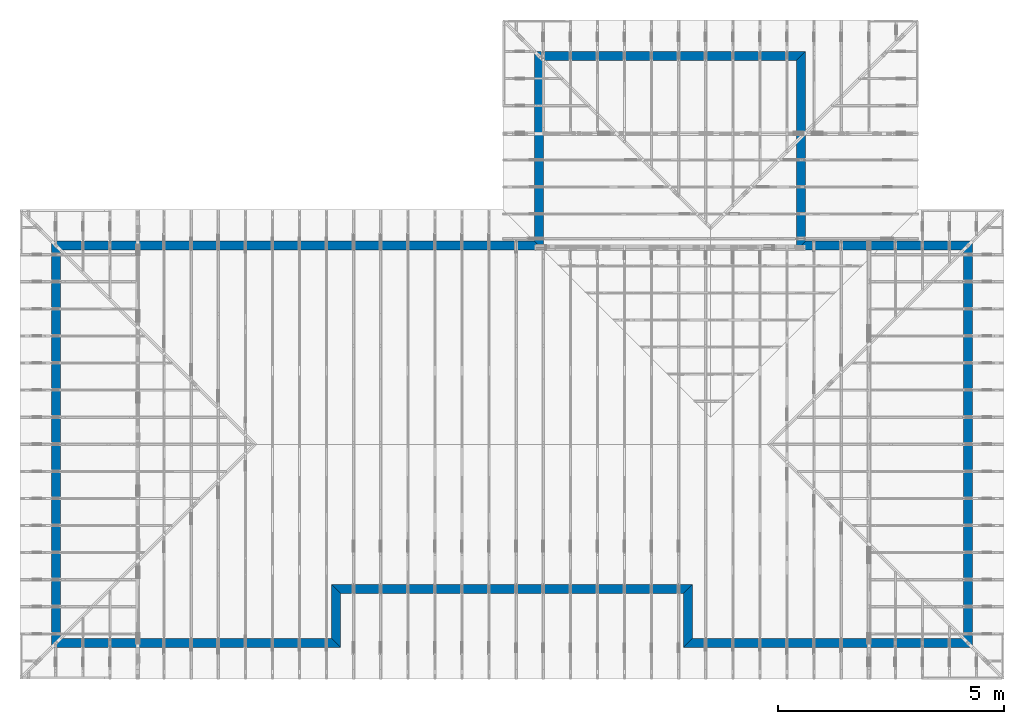
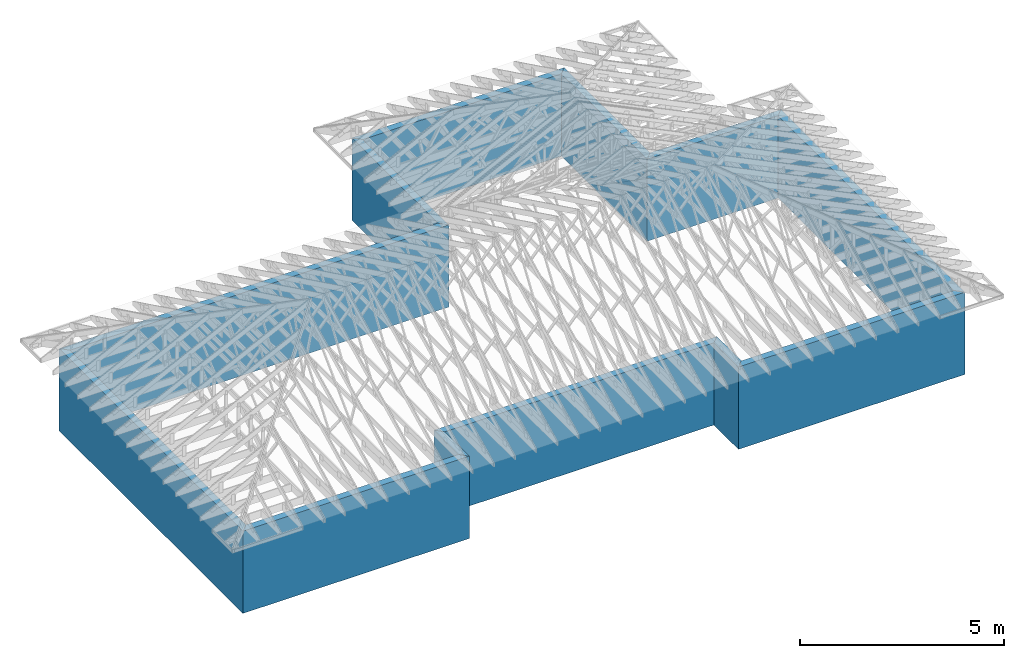
# One storey, part 1 of 159: 12 walls.
"""IFC2X3 building model written with IfcOpenShell, lengths in millimetres."""

from ifc_helpers import new_model, si_unit, frame, origin, origin_with_axes, origin_2d, place, context, project, spatial, polyline, segment, composite_curve, outline, extrude, material, layer, layer_set, layer_usage, type_object, element, save


model = new_model("IFC2X3")

# Units and contexts
model_context = context("Model", 3, precision=1e-05, world=origin())
plan_context = context("Plan", 2, precision=1e-05, world=origin_2d())
ifc_project = project(units=[si_unit("LENGTHUNIT", "METRE", prefix="MILLI"), si_unit("AREAUNIT", "SQUARE_METRE"), si_unit("VOLUMEUNIT", "CUBIC_METRE"), si_unit("SOLIDANGLEUNIT", "STERADIAN"), si_unit("PLANEANGLEUNIT", "RADIAN"), si_unit("MASSUNIT", "GRAM"), si_unit("TIMEUNIT", "SECOND"), si_unit("THERMODYNAMICTEMPERATUREUNIT", "DEGREE_CELSIUS"), si_unit("LUMINOUSINTENSITYUNIT", "LUMEN")], contexts=[model_context, plan_context])

# Site, building, storey
site_placement = place(None, origin_with_axes())
site = spatial("IfcSite", under=ifc_project, at=site_placement, CompositionType="ELEMENT")
building_placement = place(site_placement, origin_with_axes())
building = spatial("IfcBuilding", under=site, at=building_placement, Name="Plan 1", CompositionType="ELEMENT")
storey_placement = place(building_placement, origin_with_axes())
storey = spatial("IfcBuildingStorey", under=building, at=storey_placement, Name="Etasje 1", CompositionType="ELEMENT", Elevation=0.0)

# Walls
ifc_material = material(Name="Framing")
ifc_layer = layer(ifc_material, 198.0)
ifc_layer_set = layer_set([ifc_layer])
ifc_layer_usage_1 = layer_usage(ifc_layer_set, "AXIS2", "POSITIVE", 0.0)
wall_type = type_object("IfcWallType", Name="YV198", PredefinedType="STANDARD", material=ifc_layer_set)
wall_1_placement = place(storey_placement, frame((14000.012695802194, 0.001069870516026506, -2458.0), z_axis=(0.0, 0.0, 1.0), x_axis=(1.0, 0.0, 0.0)))
element("IfcWallStandardCase", 1, at=wall_1_placement, inside=storey, type_object=wall_type, material=ifc_layer_usage_1, Name="Vegg 1", context=model_context, shape_type="SweptSolid", body=[
    extrude(outline(composite_curve([segment(polyline([(198.0, 198.0), (0.0, 3.560433198268598e-14)]), True, "CONTINUOUS"), segment(polyline([(0.0, 3.560433198268598e-14), (6399.999967299293, 7.18262255228197e-15)]), True, "CONTINUOUS"), segment(polyline([(6399.999967299293, 7.18262255228197e-15), (6201.999967299293, 198.0)]), True, "CONTINUOUS"), segment(polyline([(6201.999967299293, 198.0), (198.0, 198.0)]), True, "CONTINUOUS")], self_intersect=False)), origin_with_axes(), (0.0, 0.0, 1.0), 2458.0),
])
ifc_layer_usage_2 = layer_usage(ifc_layer_set, "AXIS2", "POSITIVE", 0.0)
wall_2_placement = place(storey_placement, frame((20400.012663101486, 0.001069870516026506, -2458.0), z_axis=(0.0, 0.0, 1.0), x_axis=(0.0, 1.0, 0.0)))
element("IfcWallStandardCase", 2, at=wall_2_placement, inside=storey, type_object=wall_type, material=ifc_layer_usage_2, Name="Vegg 2", context=model_context, shape_type="SweptSolid", body=[
    extrude(outline(composite_curve([segment(polyline([(198.0, 198.0), (-7.808250573893005e-14, -4.781016632513299e-30)]), True, "CONTINUOUS"), segment(polyline([(-7.808250573893005e-14, -4.781016632513299e-30), (8999.998930129477, 5.510727937115578e-13)]), True, "CONTINUOUS"), segment(polyline([(8999.998930129477, 5.510727937115578e-13), (8801.998930129477, 198.00000000000054)]), True, "CONTINUOUS"), segment(polyline([(8801.998930129477, 198.00000000000054), (198.0, 198.0)]), True, "CONTINUOUS")], self_intersect=False)), origin_with_axes(), (0.0, 0.0, 1.0), 2458.0),
])
ifc_layer_usage_3 = layer_usage(ifc_layer_set, "AXIS2", "POSITIVE", 0.0)
wall_3_placement = place(storey_placement, frame((10700.012663101486, 8999.999999999993, -2458.0), z_axis=(0.0, 0.0, 1.0), x_axis=(-1.0, 0.0, 0.0)))
element("IfcWallStandardCase", 3, at=wall_3_placement, inside=storey, type_object=wall_type, material=ifc_layer_usage_3, Name="Vegg 3", context=model_context, shape_type="SweptSolid", body=[
    extrude(outline(composite_curve([segment(polyline([(-198.00000000000003, 197.99999999999997), (0.0, 0.0)]), True, "CONTINUOUS"), segment(polyline([(0.0, 0.0), (10700.012663101494, -5.086590542244581e-13)]), True, "CONTINUOUS"), segment(polyline([(10700.012663101494, -5.086590542244581e-13), (10502.012663101494, 197.99999999999946)]), True, "CONTINUOUS"), segment(polyline([(10502.012663101494, 197.99999999999946), (-198.00000000000003, 197.99999999999997)]), True, "CONTINUOUS")], self_intersect=False)), origin_with_axes(), (0.0, 0.0, 1.0), 2458.0),
])
ifc_layer_usage_4 = layer_usage(ifc_layer_set, "AXIS2", "POSITIVE", 0.0)
wall_4_placement = place(storey_placement, frame((-7.105427357601002e-12, 8999.999999999993, -2458.0), z_axis=(0.0, 0.0, 1.0), x_axis=(-1.836909530733566e-16, -1.0, 0.0)))
element("IfcWallStandardCase", 4, at=wall_4_placement, inside=storey, type_object=wall_type, material=ifc_layer_usage_4, Name="Vegg 4", context=model_context, shape_type="SweptSolid", body=[
    extrude(outline(composite_curve([segment(polyline([(197.99999999999815, 198.0), (-1.8189894035458565e-12, 2.8421709430403673e-14)]), True, "CONTINUOUS"), segment(polyline([(-1.8189894035458565e-12, 2.8421709430403673e-14), (8999.998930129477, 4.7592341712408726e-15)]), True, "CONTINUOUS"), segment(polyline([(8999.998930129477, 4.7592341712408726e-15), (8801.998930129477, 198.0)]), True, "CONTINUOUS"), segment(polyline([(8801.998930129477, 198.0), (197.99999999999815, 198.0)]), True, "CONTINUOUS")], self_intersect=False)), origin_with_axes(), (0.0, 0.0, 1.0), 2458.0),
])
ifc_layer_usage_5 = layer_usage(ifc_layer_set, "AXIS2", "POSITIVE", 0.0)
wall_5_placement = place(storey_placement, frame((-7.105427357601002e-12, 0.001069870516026506, -2458.0), z_axis=(0.0, 0.0, 1.0), x_axis=(1.0, 0.0, 0.0)))
element("IfcWallStandardCase", 5, at=wall_5_placement, inside=storey, type_object=wall_type, material=ifc_layer_usage_5, Name="Vegg 5", context=model_context, shape_type="SweptSolid", body=[
    extrude(outline(composite_curve([segment(polyline([(197.99999999999892, 198.0), (-1.1368683772161603e-12, 7.18262255228197e-15)]), True, "CONTINUOUS"), segment(polyline([(-1.1368683772161603e-12, 7.18262255228197e-15), (6400.138002854425, 7.18262255228197e-15)]), True, "CONTINUOUS"), segment(polyline([(6400.138002854425, 7.18262255228197e-15), (6202.138002854425, 198.0)]), True, "CONTINUOUS"), segment(polyline([(6202.138002854425, 198.0), (197.99999999999892, 198.0)]), True, "CONTINUOUS")], self_intersect=False)), origin_with_axes(), (0.0, 0.0, 1.0), 2458.0),
])
ifc_layer_usage_6 = layer_usage(ifc_layer_set, "AXIS2", "POSITIVE", 0.0)
wall_6_placement = place(storey_placement, frame((14000.012695802194, 1199.9231318597535, -2458.0), z_axis=(0.0, 0.0, 1.0), x_axis=(0.0, -1.0, 0.0)))
element("IfcWallStandardCase", 6, at=wall_6_placement, inside=storey, type_object=wall_type, material=ifc_layer_usage_6, Name="Vegg 6", context=model_context, shape_type="SweptSolid", body=[
    extrude(outline(composite_curve([segment(polyline([(-198.00000000000003, 197.99999999999997), (0.0, 0.0)]), True, "CONTINUOUS"), segment(polyline([(0.0, 0.0), (1199.9220619892376, 2.204148271805503e-13)]), True, "CONTINUOUS"), segment(polyline([(1199.9220619892376, 2.204148271805503e-13), (1001.9220619892376, 198.00000000000017)]), True, "CONTINUOUS"), segment(polyline([(1001.9220619892376, 198.00000000000017), (-198.00000000000003, 197.99999999999997)]), True, "CONTINUOUS")], self_intersect=False)), origin_with_axes(), (0.0, 0.0, 1.0), 2458.0),
])
ifc_layer_usage_7 = layer_usage(ifc_layer_set, "AXIS2", "POSITIVE", 0.0)
wall_7_placement = place(storey_placement, frame((6400.138002854418, 1199.9231318597535, -2458.0), z_axis=(0.0, 0.0, 1.0), x_axis=(1.0, 0.0, 0.0)))
element("IfcWallStandardCase", 7, at=wall_7_placement, inside=storey, type_object=wall_type, material=ifc_layer_usage_7, Name="Vegg 7", context=model_context, shape_type="SweptSolid", body=[
    extrude(outline(composite_curve([segment(polyline([(-198.0, 198.0), (0.0, 0.0)]), True, "CONTINUOUS"), segment(polyline([(0.0, 0.0), (7599.874692947776, 0.0)]), True, "CONTINUOUS"), segment(polyline([(7599.874692947776, 0.0), (7797.874692947776, 198.0)]), True, "CONTINUOUS"), segment(polyline([(7797.874692947776, 198.0), (-198.0, 198.0)]), True, "CONTINUOUS")], self_intersect=False)), origin_with_axes(), (0.0, 0.0, 1.0), 2458.0),
])
ifc_layer_usage_8 = layer_usage(ifc_layer_set, "AXIS2", "POSITIVE", 0.0)
wall_8_placement = place(storey_placement, frame((6400.138002854418, 0.0010698705159484234, -2458.0), z_axis=(0.0, 0.0, 1.0), x_axis=(0.0, 1.0, 0.0)))
element("IfcWallStandardCase", 8, at=wall_8_placement, inside=storey, type_object=wall_type, material=ifc_layer_usage_8, Name="Vegg 8", context=model_context, shape_type="SweptSolid", body=[
    extrude(outline(composite_curve([segment(polyline([(198.00000000000009, 198.0), (0.0, 0.0)]), True, "CONTINUOUS"), segment(polyline([(0.0, 0.0), (1199.9220619892374, 7.347160906018343e-14)]), True, "CONTINUOUS"), segment(polyline([(1199.9220619892374, 7.347160906018343e-14), (1397.9220619892376, 198.00000000000009)]), True, "CONTINUOUS"), segment(polyline([(1397.9220619892376, 198.00000000000009), (198.00000000000009, 198.0)]), True, "CONTINUOUS")], self_intersect=False)), origin_with_axes(), (0.0, 0.0, 1.0), 2458.0),
])
ifc_layer_usage_9 = layer_usage(ifc_layer_set, "AXIS2", "POSITIVE", 0.0)
wall_9_placement = place(storey_placement, frame((20400.012663101486, 8999.999999999993, -2458.0), z_axis=(0.0, 0.0, 1.0), x_axis=(-1.0, 0.0, 0.0)))
element("IfcWallStandardCase", 9, at=wall_9_placement, inside=storey, type_object=wall_type, material=ifc_layer_usage_9, Name="Vegg 9", context=model_context, shape_type="SweptSolid", body=[
    extrude(outline(composite_curve([segment(polyline([(197.99999999999997, 198.00000000000003), (0.0, 0.0)]), True, "CONTINUOUS"), segment(polyline([(0.0, 0.0), (3700.0000000000073, 4.531043509142805e-13)]), True, "CONTINUOUS"), segment(polyline([(3700.0000000000073, 4.531043509142805e-13), (3898.0000000000073, 198.00000000000048)]), True, "CONTINUOUS"), segment(polyline([(3898.0000000000073, 198.00000000000048), (197.99999999999997, 198.00000000000003)]), True, "CONTINUOUS")], self_intersect=False)), origin_with_axes(), (0.0, 0.0, 1.0), 2458.0),
])
ifc_layer_usage_10 = layer_usage(ifc_layer_set, "AXIS2", "POSITIVE", 0.0)
wall_10_placement = place(storey_placement, frame((16700.01266310148, 8999.999999999993, -2458.0), z_axis=(0.0, 0.0, 1.0), x_axis=(0.0, 1.0, 0.0)))
element("IfcWallStandardCase", 10, at=wall_10_placement, inside=storey, type_object=wall_type, material=ifc_layer_usage_10, Name="Vegg 10", context=model_context, shape_type="SweptSolid", body=[
    extrude(outline(composite_curve([segment(polyline([(-198.0, 198.0), (0.0, 0.0)]), True, "CONTINUOUS"), segment(polyline([(0.0, 0.0), (4199.999978540165, 2.571673329887067e-13)]), True, "CONTINUOUS"), segment(polyline([(4199.999978540165, 2.571673329887067e-13), (4001.999978540165, 198.00000000000026)]), True, "CONTINUOUS"), segment(polyline([(4001.999978540165, 198.00000000000026), (-198.0, 198.0)]), True, "CONTINUOUS")], self_intersect=False)), origin_with_axes(), (0.0, 0.0, 1.0), 2458.0),
])
ifc_layer_usage_11 = layer_usage(ifc_layer_set, "AXIS2", "POSITIVE", 0.0)
wall_11_placement = place(storey_placement, frame((16700.01266310148, 13199.999978540158, -2458.0), z_axis=(0.0, 0.0, 1.0), x_axis=(-1.0, 0.0, 0.0)))
element("IfcWallStandardCase", 11, at=wall_11_placement, inside=storey, type_object=wall_type, material=ifc_layer_usage_11, Name="Vegg 11", context=model_context, shape_type="SweptSolid", body=[
    extrude(outline(composite_curve([segment(polyline([(197.99999999999997, 198.00000000000003), (0.0, 0.0)]), True, "CONTINUOUS"), segment(polyline([(0.0, 0.0), (5999.999999999993, 7.347638122934254e-13)]), True, "CONTINUOUS"), segment(polyline([(5999.999999999993, 7.347638122934254e-13), (5801.999999999993, 198.0000000000007)]), True, "CONTINUOUS"), segment(polyline([(5801.999999999993, 198.0000000000007), (197.99999999999997, 198.00000000000003)]), True, "CONTINUOUS")], self_intersect=False)), origin_with_axes(), (0.0, 0.0, 1.0), 2458.0),
])
ifc_layer_usage_12 = layer_usage(ifc_layer_set, "AXIS2", "POSITIVE", 0.0)
wall_12_placement = place(storey_placement, frame((10700.012663101486, 13199.999978540158, -2458.0), z_axis=(0.0, 0.0, 1.0), x_axis=(0.0, -1.0, 0.0)))
element("IfcWallStandardCase", 12, at=wall_12_placement, inside=storey, type_object=wall_type, material=ifc_layer_usage_12, Name="Vegg 12", context=model_context, shape_type="SweptSolid", body=[
    extrude(outline(composite_curve([segment(polyline([(197.99999999999997, 198.00000000000003), (0.0, 0.0)]), True, "CONTINUOUS"), segment(polyline([(0.0, 0.0), (4199.999978540165, 7.715019989661202e-13)]), True, "CONTINUOUS"), segment(polyline([(4199.999978540165, 7.715019989661202e-13), (4397.999978540165, 198.0000000000008)]), True, "CONTINUOUS"), segment(polyline([(4397.999978540165, 198.0000000000008), (197.99999999999997, 198.00000000000003)]), True, "CONTINUOUS")], self_intersect=False)), origin_with_axes(), (0.0, 0.0, 1.0), 2458.0),
])

save(model, "model.ifc")
